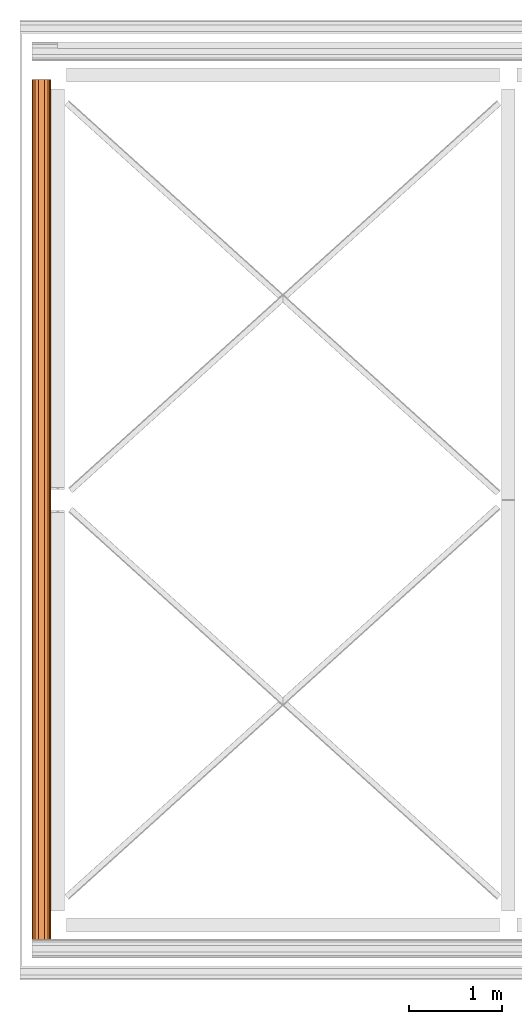
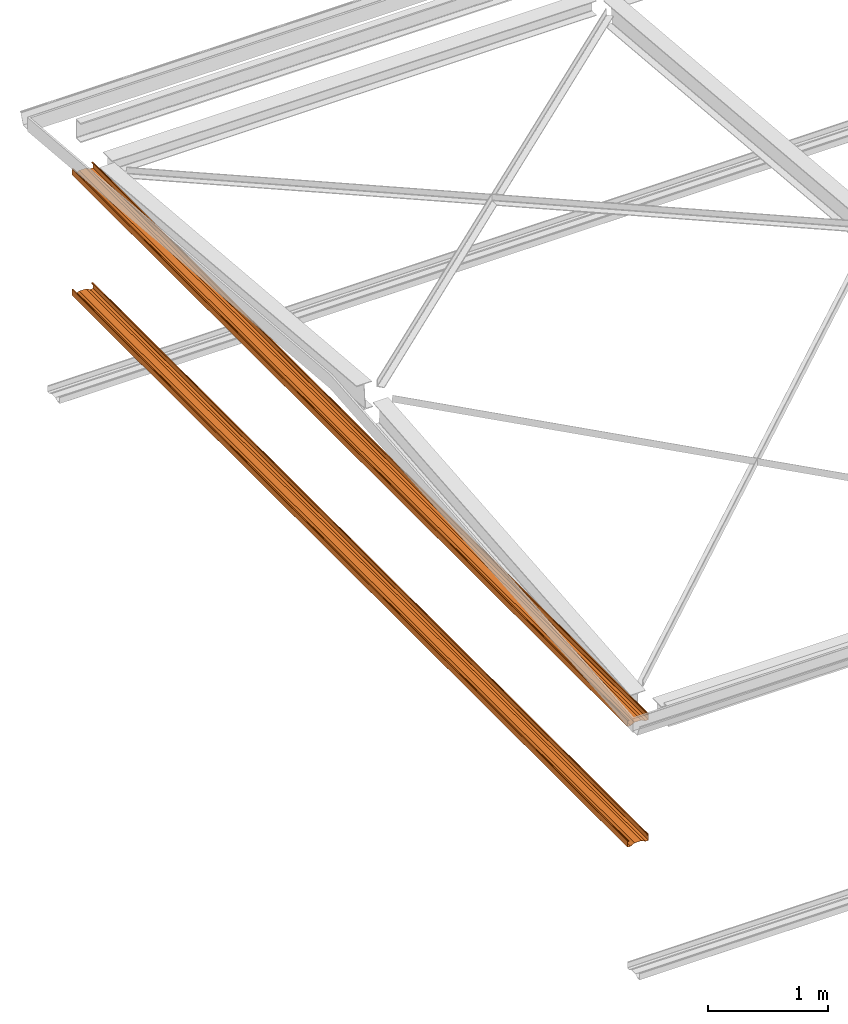
# One storey, part 5 of 8: 2 proxies.
"""IFC2X3 building model written with IfcOpenShell, lengths in millimetres."""

from ifc_helpers import new_model, entity, si_unit, converted_unit, money_unit, direction, frame, origin_with_axes, place, context, subcontext, project, spatial, faceted_brep, source, transform, mapped, material, type_object, element, save


model = new_model("IFC2X3")

# Units and contexts
model_context = context("Model", 3, precision=1e-05, world=origin_with_axes(), true_north=direction((0.0, 1.0)))
body_context = subcontext(model_context, "Body", "Model", "MODEL_VIEW")
ifc_project = project(units=[si_unit("LENGTHUNIT", "METRE", prefix="MILLI"), si_unit("AREAUNIT", "SQUARE_METRE"), si_unit("VOLUMEUNIT", "CUBIC_METRE"), converted_unit("PLANEANGLEUNIT", "DEGREE", entity("IfcPlaneAngleMeasure", 0.0174532925199), si_unit("PLANEANGLEUNIT", "RADIAN"), dimensions=[0, 0, 0, 0, 0, 0, 0]), si_unit("SOLIDANGLEUNIT", "STERADIAN"), money_unit("USD"), converted_unit("TIMEUNIT", "Year", entity("IfcTimeMeasure", 31556926.0), si_unit("TIMEUNIT", "SECOND"), dimensions=[0, 0, 0, 0, 0, 0, 0]), si_unit("MASSUNIT", "GRAM"), si_unit("THERMODYNAMICTEMPERATUREUNIT", "DEGREE_CELSIUS"), si_unit("LUMINOUSINTENSITYUNIT", "LUMEN")], contexts=[model_context])

# Site, building, storey
site_placement = place(None, origin_with_axes())
site = spatial("IfcSite", under=ifc_project, at=site_placement, CompositionType="ELEMENT")
building_placement = place(site_placement, origin_with_axes())
building = spatial("IfcBuilding", under=site, at=building_placement, CompositionType="ELEMENT")
storey_placement = place(building_placement, frame((0.0, 0.0, 74215.0), z_axis=(0.0, 0.0, 1.0), x_axis=(1.0, 0.0, 0.0)))
storey = spatial("IfcBuildingStorey", under=building, at=storey_placement, CompositionType="ELEMENT", Elevation=74215.0)

# Proxies
ifc_material = material(Name="Metal - Steel 43-275")
building_element_proxy_type = type_object("IfcBuildingElementProxyType", Name="M", PredefinedType="USERDEFINED")
shared_shape = source(origin_with_axes(), body_context, "Body", "Brep", [
    faceted_brep([(4745.5, -70.5, 0.0), (4745.5, -99.3, 0.0), (-4501.5, -99.3, 0.0), (-4501.5, -70.5, 0.0), (4745.5, -32.5, 20.0), (4745.5, 32.5, 20.0), (4745.5, 70.5, 0.0), (4745.5, 99.3, 0.0), (4745.5, 100.524586984, 0.24358549596), (4745.5, 101.5627417, 0.9372583002), (4745.5, 102.256414504, 1.97541301643), (4745.5, 102.5, 3.2), (4745.5, 102.5, 61.8), (4745.5, 102.256414504, 63.0245869836), (4745.5, 101.5627417, 64.0627416998), (4745.5, 100.524586984, 64.756414504), (4745.5, 99.3, 65.0), (4745.5, 91.7, 65.0), (4745.5, 90.4754130164, 64.756414504), (4745.5, 89.4372583002, 64.0627416998), (4745.5, 88.743585496, 63.0245869836), (4745.5, 88.5, 61.8), (4745.5, 88.5, 53.0), (4745.5, 90.1, 53.0), (4745.5, 90.1, 61.8), (4745.5, 90.221792748, 62.4122934918), (4745.5, 90.5686291501, 62.9313708499), (4745.5, 91.0877065082, 63.278207252), (4745.5, 91.7, 63.4), (4745.5, 99.3, 63.4), (4745.5, 99.9122934918, 63.278207252), (4745.5, 100.43137085, 62.9313708499), (4745.5, 100.778207252, 62.4122934918), (4745.5, 100.9, 61.8), (4745.5, 100.9, 3.19999999999), (4745.5, 100.778207252, 2.58770650821), (4745.5, 100.43137085, 2.0686291501), (4745.5, 99.9122934918, 1.72179274798), (4745.5, 99.3, 1.6), (4745.5, 70.8953456886, 1.6), (4745.5, 32.8953456886, 21.6), (4745.5, -32.8953456886, 21.6), (4745.5, -70.8953456886, 1.6), (4745.5, -99.3, 1.6), (4745.5, -99.9122934918, 1.72179274798), (4745.5, -100.43137085, 2.0686291501), (4745.5, -100.778207252, 2.58770650821), (4745.5, -100.9, 3.19999999999), (4745.5, -100.9, 61.8), (4745.5, -100.778207252, 62.4122934918), (4745.5, -100.43137085, 62.9313708499), (4745.5, -99.9122934918, 63.278207252), (4745.5, -99.3, 63.4), (4745.5, -91.7, 63.4), (4745.5, -91.0877065082, 63.278207252), (4745.5, -90.5686291501, 62.9313708499), (4745.5, -90.221792748, 62.4122934918), (4745.5, -90.1, 61.8), (4745.5, -90.1, 53.0), (4745.5, -88.5, 53.0), (4745.5, -88.5, 61.8), (4745.5, -88.743585496, 63.0245869836), (4745.5, -89.4372583002, 64.0627416998), (4745.5, -90.4754130164, 64.756414504), (4745.5, -91.7, 65.0), (4745.5, -99.3, 65.0), (4745.5, -100.524586984, 64.756414504), (4745.5, -101.5627417, 64.0627416998), (4745.5, -102.256414504, 63.0245869836), (4745.5, -102.5, 61.8), (4745.5, -102.5, 3.19999999999), (4745.5, -102.256414504, 1.97541301643), (4745.5, -101.5627417, 0.9372583002), (4745.5, -100.524586984, 0.24358549596), (-4501.5, -100.524586984, 0.24358549596), (-4501.5, -101.5627417, 0.9372583002), (-4501.5, -102.256414504, 1.97541301643), (-4501.5, -102.5, 3.19999999999), (-4501.5, -102.5, 61.8), (-4501.5, -102.256414504, 63.0245869836), (-4501.5, -101.5627417, 64.0627416998), (-4501.5, -100.524586984, 64.756414504), (-4501.5, -99.3, 65.0), (-4501.5, -91.7, 65.0), (-4501.5, -90.4754130164, 64.756414504), (-4501.5, -89.4372583002, 64.0627416998), (-4501.5, -88.743585496, 63.0245869836), (-4501.5, -88.5, 61.8), (-4501.5, -88.5, 53.0), (-4501.5, -90.1, 53.0), (-4501.5, -90.1, 61.8), (-4501.5, -90.221792748, 62.4122934918), (-4501.5, -90.5686291501, 62.9313708499), (-4501.5, -91.0877065082, 63.278207252), (-4501.5, -91.7, 63.4), (-4501.5, -99.3, 63.4), (-4501.5, -99.9122934918, 63.278207252), (-4501.5, -100.43137085, 62.9313708499), (-4501.5, -100.778207252, 62.4122934918), (-4501.5, -100.9, 61.8), (-4501.5, -100.9, 3.19999999999), (-4501.5, -100.778207252, 2.58770650821), (-4501.5, -100.43137085, 2.0686291501), (-4501.5, -99.9122934918, 1.72179274798), (-4501.5, -99.3, 1.6), (-4501.5, -70.8953456886, 1.6), (-4501.5, -32.8953456886, 21.6), (-4501.5, 32.8953456886, 21.6), (-4501.5, 70.8953456886, 1.6), (-4501.5, 99.3, 1.6), (-4501.5, 99.9122934918, 1.72179274798), (-4501.5, 100.43137085, 2.0686291501), (-4501.5, 100.778207252, 2.58770650821), (-4501.5, 100.9, 3.19999999999), (-4501.5, 100.9, 61.8), (-4501.5, 100.778207252, 62.4122934918), (-4501.5, 100.43137085, 62.9313708499), (-4501.5, 99.9122934918, 63.278207252), (-4501.5, 99.3, 63.4), (-4501.5, 91.7, 63.4), (-4501.5, 91.0877065082, 63.278207252), (-4501.5, 90.5686291501, 62.9313708499), (-4501.5, 90.221792748, 62.4122934918), (-4501.5, 90.1, 61.8), (-4501.5, 90.1, 53.0), (-4501.5, 88.5, 53.0), (-4501.5, 88.5, 61.8), (-4501.5, 88.743585496, 63.0245869836), (-4501.5, 89.4372583002, 64.0627416998), (-4501.5, 90.4754130164, 64.756414504), (-4501.5, 91.7, 65.0), (-4501.5, 99.3, 65.0), (-4501.5, 100.524586984, 64.756414504), (-4501.5, 101.5627417, 64.0627416998), (-4501.5, 102.256414504, 63.0245869836), (-4501.5, 102.5, 61.8), (-4501.5, 102.5, 3.2), (-4501.5, 102.256414504, 1.97541301643), (-4501.5, 101.5627417, 0.9372583002), (-4501.5, 100.524586984, 0.24358549596), (-4501.5, 99.3, 0.0), (-4501.5, 70.5, 0.0), (-4501.5, 32.5, 20.0), (-4501.5, -32.5, 20.0)], [[[0, 1, 2, 3]], [[0, 4, 5, 6, 7, 8, 9, 10, 11, 12, 13, 14, 15, 16, 17, 18, 19, 20, 21, 22, 23, 24, 25, 26, 27, 28, 29, 30, 31, 32, 33, 34, 35, 36, 37, 38, 39, 40, 41, 42, 43, 44, 45, 46, 47, 48, 49, 50, 51, 52, 53, 54, 55, 56, 57, 58, 59, 60, 61, 62, 63, 64, 65, 66, 67, 68, 69, 70, 71, 72, 73, 1]], [[1, 73, 74, 2]], [[3, 2, 74, 75, 76, 77, 78, 79, 80, 81, 82, 83, 84, 85, 86, 87, 88, 89, 90, 91, 92, 93, 94, 95, 96, 97, 98, 99, 100, 101, 102, 103, 104, 105, 106, 107, 108, 109, 110, 111, 112, 113, 114, 115, 116, 117, 118, 119, 120, 121, 122, 123, 124, 125, 126, 127, 128, 129, 130, 131, 132, 133, 134, 135, 136, 137, 138, 139, 140, 141, 142, 143]], [[4, 0, 3, 143]], [[5, 4, 143, 142]], [[6, 5, 142, 141]], [[7, 6, 141, 140]], [[8, 7, 140, 139]], [[9, 8, 139, 138]], [[10, 9, 138, 137]], [[11, 10, 137, 136]], [[12, 11, 136, 135]], [[13, 12, 135, 134]], [[14, 13, 134, 133]], [[15, 14, 133, 132]], [[16, 15, 132, 131]], [[17, 16, 131, 130]], [[18, 17, 130, 129]], [[19, 18, 129, 128]], [[20, 19, 128, 127]], [[21, 20, 127, 126]], [[22, 21, 126, 125]], [[23, 22, 125, 124]], [[24, 23, 124, 123]], [[25, 24, 123, 122]], [[26, 25, 122, 121]], [[27, 26, 121, 120]], [[28, 27, 120, 119]], [[29, 28, 119, 118]], [[30, 29, 118, 117]], [[31, 30, 117, 116]], [[32, 31, 116, 115]], [[33, 32, 115, 114]], [[34, 33, 114, 113]], [[35, 34, 113, 112]], [[36, 35, 112, 111]], [[37, 36, 111, 110]], [[38, 37, 110, 109]], [[39, 38, 109, 108]], [[40, 39, 108, 107]], [[41, 40, 107, 106]], [[42, 41, 106, 105]], [[43, 42, 105, 104]], [[44, 43, 104, 103]], [[45, 44, 103, 102]], [[46, 45, 102, 101]], [[47, 46, 101, 100]], [[48, 47, 100, 99]], [[49, 48, 99, 98]], [[50, 49, 98, 97]], [[51, 50, 97, 96]], [[52, 51, 96, 95]], [[53, 52, 95, 94]], [[54, 53, 94, 93]], [[55, 54, 93, 92]], [[56, 55, 92, 91]], [[57, 56, 91, 90]], [[58, 57, 90, 89]], [[59, 58, 89, 88]], [[60, 59, 88, 87]], [[61, 60, 87, 86]], [[62, 61, 86, 85]], [[63, 62, 85, 84]], [[64, 63, 84, 83]], [[65, 64, 83, 82]], [[66, 65, 82, 81]], [[67, 66, 81, 80]], [[68, 67, 80, 79]], [[69, 68, 79, 78]], [[70, 69, 78, 77]], [[71, 70, 77, 76]], [[72, 71, 76, 75]], [[73, 72, 75, 74]]]),
])
for number, where, z_axis, x_axis, name in (
    (1, (-8295.42046281, 3597.47992169, -65.0), (0.0, 0.0, 1.0), (0.0, -1.0, 0.0), "Light Gauge-Kingspan Rails:M"),
    (2, (-8295.42046281, 3597.47992169, -1290.0), (0.0, 0.0, 1.0), (0.0, -1.0, 0.0), "Light Gauge-Kingspan Rails:M"),
):
    element("IfcBuildingElementProxy", number, at=place(storey_placement, frame(where, z_axis=z_axis, x_axis=x_axis)), inside=storey, type_object=building_element_proxy_type, material=ifc_material, Name=name, ObjectType="M", context=body_context, shape_type="MappedRepresentation", body=[
        mapped(shared_shape, transform((0.0, 0.0, 0.0))),
    ])

save(model, "model.ifc")
